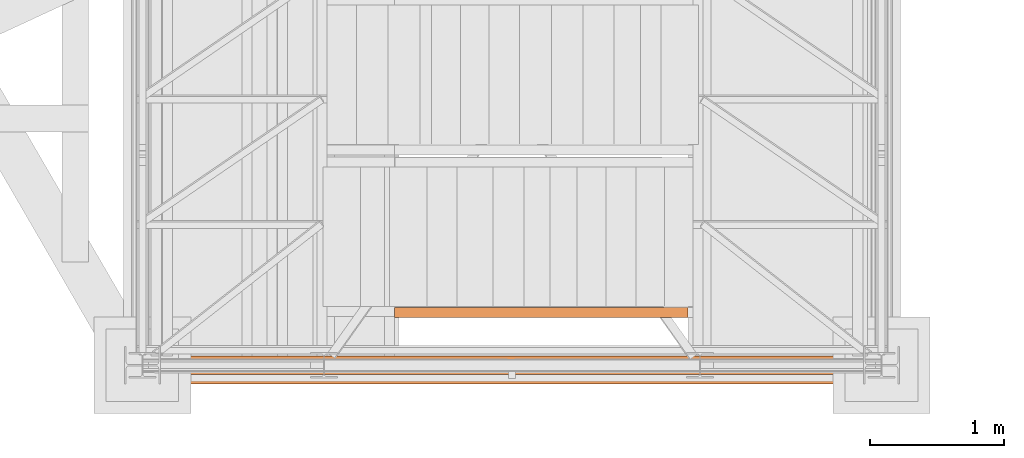
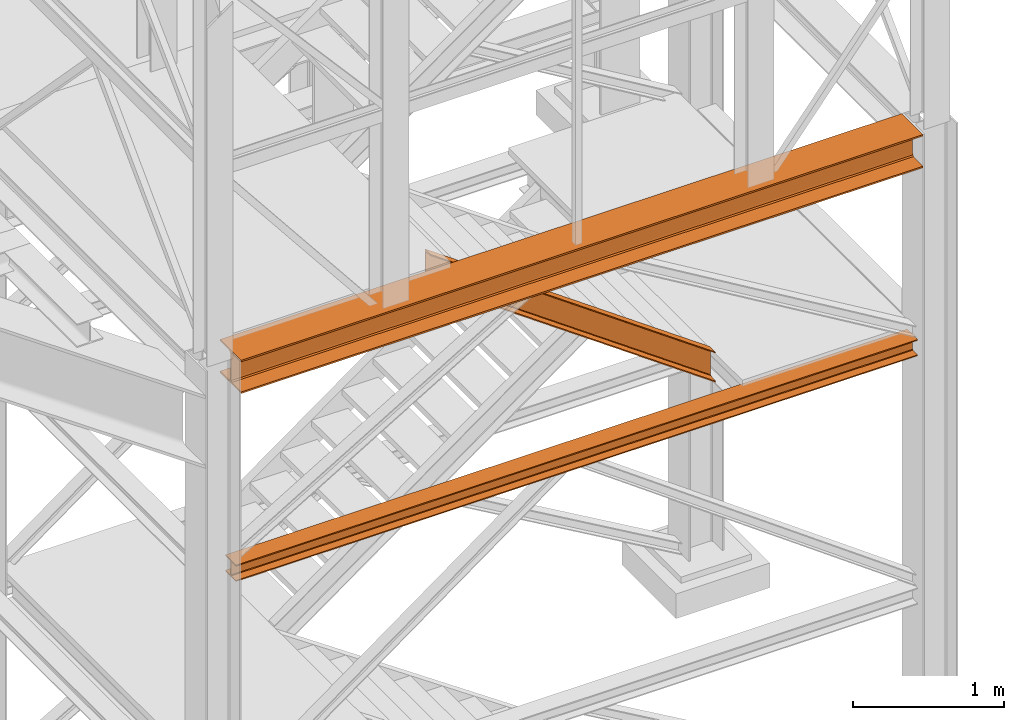
# One storey, part 41 of 208: 3 proxies.
"""IFC2X3 building model written with IfcOpenShell, lengths in millimetres."""

from ifc_helpers import new_model, entity, si_unit, converted_unit, frame, origin, origin_with_axes, place, context, subcontext, project, spatial, faceted_brep, element, save


model = new_model("IFC2X3")

# Units and contexts
model_context = context("Model", 3, precision=1e-05, world=origin())
plan_context = context("Plan", 3, precision=1e-05, world=origin())
body_context = subcontext(model_context, "Body", "Model", "MODEL_VIEW")
ifc_project = project(units=[si_unit("LENGTHUNIT", "METRE", prefix="MILLI"), converted_unit("PLANEANGLEUNIT", "DEGREE", entity("IfcPlaneAngleMeasure", 0.0174532925199433), si_unit("PLANEANGLEUNIT", "RADIAN"), dimensions=[0, 0, 0, 0, 0, 0, 0]), si_unit("AREAUNIT", "SQUARE_METRE"), si_unit("VOLUMEUNIT", "CUBIC_METRE")], contexts=[model_context, plan_context])

# Building, storey
building_placement = place(None, origin())
building = spatial("IfcBuilding", under=ifc_project, at=building_placement, CompositionType="COMPLEX")
storey_placement = place(building_placement, origin_with_axes())
storey = spatial("IfcBuildingStorey", under=building, at=storey_placement, Name="Geschoss", CompositionType="ELEMENT")

# Proxies
proxy_1_placement = place(storey_placement, frame((1333.254973893081, -25242.57439061591, 3447.489998909947), z_axis=(0.0, 0.0, 1.0), x_axis=(1.0, 0.0, 0.0)))
element("IfcBuildingElementProxy", 1, at=proxy_1_placement, inside=storey, context=body_context, shape_type="Brep", body=[
    faceted_brep([(0.01000000000021828, 0.01000000000567525, 8.510002324581365), (0.01000000000021828, 0.01000000000567525, 0.01000000000021828), (0.01000000000021828, 140.0100005960521, 0.01000000000021828), (0.01000000000021828, 140.0100005960521, 8.510002324581365), (0.01000000000021828, 84.76000038743587, 8.510002324581365), (0.01000000000021828, 78.54945996612878, 9.753034839630345), (0.01000000000021828, 74.00303279817672, 14.29946480155013), (0.01000000000021828, 72.76000051595838, 20.51000429153464), (0.01000000000021828, 72.76000051595838, 112.5100007450583), (0.01000000000021828, 74.00303279817672, 118.7205402350428), (0.01000000000021828, 78.54945996612878, 123.2669664716723), (0.01000000000021828, 84.76000038743587, 124.5099989867213), (0.01000000000021828, 140.0100005960521, 124.5099989867213), (0.01000000000021828, 140.0100005960521, 133.0100013113024), (0.01000000000021828, 0.01000000000567525, 133.0100013113024), (0.01000000000021828, 0.01000000000567525, 124.5099989867213), (0.01000000000021828, 55.26000020862193, 124.5099989867213), (0.01000000000021828, 61.47054062992902, 123.2669664716723), (0.01000000000021828, 66.01696779788108, 118.7205402350428), (0.01000000000021828, 67.26000008009942, 112.5100007450583), (0.01000000000021828, 67.26000008009942, 20.51000429153464), (0.01000000000021828, 66.01696779788108, 14.29946480155013), (0.01000000000021828, 61.47054062992902, 9.753034839630345), (0.01000000000021828, 55.26000020862193, 8.510002324581365), (0.01000000000021828, 0.01000000000567525, 0.01000000000021828), (0.01000000000021828, 0.01000000000567525, 8.510002324581365), (5230.009989271167, 0.01000000000203727, 8.510002324581365), (5230.009989271167, 0.01000000000203727, 0.01000000000021828), (0.01000000000021828, 140.0100005960521, 0.01000000000021828), (0.01000000000021828, 0.01000000000567525, 0.01000000000021828), (5230.009989271167, 0.01000000000203727, 0.01000000000021828), (5230.009989271167, 140.0100005960485, 0.01000000000021828), (0.01000000000021828, 140.0100005960521, 8.510002324581365), (0.01000000000021828, 140.0100005960521, 0.01000000000021828), (5230.009989271167, 140.0100005960485, 0.01000000000021828), (5230.009989271167, 140.0100005960485, 8.510002324581365), (0.01000000000021828, 84.76000038743587, 8.510002324581365), (0.01000000000021828, 140.0100005960521, 8.510002324581365), (5230.009989271167, 140.0100005960485, 8.510002324581365), (5230.009989271167, 84.76000038743223, 8.510002324581365), (0.01000000000021828, 78.54945996612878, 9.753034839630345), (0.01000000000021828, 84.76000038743587, 8.510002324581365), (5230.009989271167, 84.76000038743223, 8.510002324581365), (5230.009989271167, 78.54945996612514, 9.753034839630345), (0.01000000000021828, 74.00303279817672, 14.29946480155013), (0.01000000000021828, 78.54945996612878, 9.753034839630345), (5230.009989271167, 78.54945996612514, 9.753034839630345), (5230.009989271167, 74.00303279817308, 14.29946480155013), (0.01000000000021828, 72.76000051595838, 20.51000429153464), (0.01000000000021828, 74.00303279817672, 14.29946480155013), (5230.009989271167, 74.00303279817308, 14.29946480155013), (5230.009989271167, 72.76000051595474, 20.51000429153464), (0.01000000000021828, 72.76000051595838, 112.5100007450583), (0.01000000000021828, 72.76000051595838, 20.51000429153464), (5230.009989271167, 72.76000051595474, 20.51000429153464), (5230.009989271167, 72.76000051595474, 112.5100007450583), (0.01000000000021828, 74.00303279817672, 118.7205402350428), (0.01000000000021828, 72.76000051595838, 112.5100007450583), (5230.009989271167, 72.76000051595474, 112.5100007450583), (5230.009989271167, 74.00303279817308, 118.7205402350428), (0.01000000000021828, 78.54945996612878, 123.2669664716723), (0.01000000000021828, 74.00303279817672, 118.7205402350428), (5230.009989271167, 74.00303279817308, 118.7205402350428), (5230.009989271167, 78.54945996612514, 123.2669664716723), (0.01000000000021828, 84.76000038743587, 124.5099989867213), (0.01000000000021828, 78.54945996612878, 123.2669664716723), (5230.009989271167, 78.54945996612514, 123.2669664716723), (5230.009989271167, 84.76000038743223, 124.5099989867213), (0.01000000000021828, 140.0100005960521, 124.5099989867213), (0.01000000000021828, 84.76000038743587, 124.5099989867213), (5230.009989271167, 84.76000038743223, 124.5099989867213), (5230.009989271167, 140.0100005960485, 124.5099989867213), (0.01000000000021828, 140.0100005960521, 133.0100013113024), (0.01000000000021828, 140.0100005960521, 124.5099989867213), (5230.009989271167, 140.0100005960485, 124.5099989867213), (5230.009989271167, 140.0100005960485, 133.0100013113024), (0.01000000000021828, 0.01000000000567525, 133.0100013113024), (0.01000000000021828, 140.0100005960521, 133.0100013113024), (5230.009989271167, 140.0100005960485, 133.0100013113024), (5230.009989271167, 0.01000000000203727, 133.0100013113024), (0.01000000000021828, 0.01000000000567525, 124.5099989867213), (0.01000000000021828, 0.01000000000567525, 133.0100013113024), (5230.009989271167, 0.01000000000203727, 133.0100013113024), (5230.009989271167, 0.01000000000203727, 124.5099989867213), (0.01000000000021828, 55.26000020862193, 124.5099989867213), (0.01000000000021828, 0.01000000000567525, 124.5099989867213), (5230.009989271167, 0.01000000000203727, 124.5099989867213), (5230.009989271167, 55.26000020861829, 124.5099989867213), (0.01000000000021828, 61.47054062992902, 123.2669664716723), (0.01000000000021828, 55.26000020862193, 124.5099989867213), (5230.009989271167, 55.26000020861829, 124.5099989867213), (5230.009989271167, 61.47054062992538, 123.2669664716723), (0.01000000000021828, 66.01696779788108, 118.7205402350428), (0.01000000000021828, 61.47054062992902, 123.2669664716723), (5230.009989271167, 61.47054062992538, 123.2669664716723), (5230.009989271167, 66.01696779787744, 118.7205402350428), (0.01000000000021828, 67.26000008009942, 112.5100007450583), (0.01000000000021828, 66.01696779788108, 118.7205402350428), (5230.009989271167, 66.01696779787744, 118.7205402350428), (5230.009989271167, 67.26000008009578, 112.5100007450583), (0.01000000000021828, 67.26000008009942, 20.51000429153464), (0.01000000000021828, 67.26000008009942, 112.5100007450583), (5230.009989271167, 67.26000008009578, 112.5100007450583), (5230.009989271167, 67.26000008009578, 20.51000429153464), (0.01000000000021828, 66.01696779788108, 14.29946480155013), (0.01000000000021828, 67.26000008009942, 20.51000429153464), (5230.009989271167, 67.26000008009578, 20.51000429153464), (5230.009989271167, 66.01696779787744, 14.29946480155013), (0.01000000000021828, 61.47054062992902, 9.753034839630345), (0.01000000000021828, 66.01696779788108, 14.29946480155013), (5230.009989271167, 66.01696779787744, 14.29946480155013), (5230.009989271167, 61.47054062992538, 9.753034839630345), (0.01000000000021828, 55.26000020862193, 8.510002324581365), (0.01000000000021828, 61.47054062992902, 9.753034839630345), (5230.009989271167, 61.47054062992538, 9.753034839630345), (5230.009989271167, 55.26000020861829, 8.510002324581365), (0.01000000000021828, 0.01000000000567525, 8.510002324581365), (0.01000000000021828, 55.26000020862193, 8.510002324581365), (5230.009989271167, 55.26000020861829, 8.510002324581365), (5230.009989271167, 0.01000000000203727, 8.510002324581365), (5230.009989271167, 0.01000000000203727, 8.510002324581365), (5230.009989271167, 55.26000020861829, 8.510002324581365), (5230.009989271167, 61.47054062992538, 9.753034839630345), (5230.009989271167, 66.01696779787744, 14.29946480155013), (5230.009989271167, 67.26000008009578, 20.51000429153464), (5230.009989271167, 67.26000008009578, 112.5100007450583), (5230.009989271167, 66.01696779787744, 118.7205402350428), (5230.009989271167, 61.47054062992538, 123.2669664716723), (5230.009989271167, 55.26000020861829, 124.5099989867213), (5230.009989271167, 0.01000000000203727, 124.5099989867213), (5230.009989271167, 0.01000000000203727, 133.0100013113024), (5230.009989271167, 140.0100005960485, 133.0100013113024), (5230.009989271167, 140.0100005960485, 124.5099989867213), (5230.009989271167, 84.76000038743223, 124.5099989867213), (5230.009989271167, 78.54945996612514, 123.2669664716723), (5230.009989271167, 74.00303279817308, 118.7205402350428), (5230.009989271167, 72.76000051595474, 112.5100007450583), (5230.009989271167, 72.76000051595474, 20.51000429153464), (5230.009989271167, 74.00303279817308, 14.29946480155013), (5230.009989271167, 78.54945996612514, 9.753034839630345), (5230.009989271167, 84.76000038743223, 8.510002324581365), (5230.009989271167, 140.0100005960485, 8.510002324581365), (5230.009989271167, 140.0100005960485, 0.01000000000021828), (5230.009989271167, 0.01000000000203727, 0.01000000000021828)], [[[0, 1, 2, 3, 4, 5, 6, 7, 8, 9, 10, 11, 12, 13, 14, 15, 16, 17, 18, 19, 20, 21, 22, 23]], [[24, 25, 26, 27]], [[28, 29, 30, 31]], [[32, 33, 34, 35]], [[36, 37, 38, 39]], [[40, 41, 42, 43]], [[44, 45, 46, 47]], [[48, 49, 50, 51]], [[52, 53, 54, 55]], [[56, 57, 58, 59]], [[60, 61, 62, 63]], [[64, 65, 66, 67]], [[68, 69, 70, 71]], [[72, 73, 74, 75]], [[76, 77, 78, 79]], [[80, 81, 82, 83]], [[84, 85, 86, 87]], [[88, 89, 90, 91]], [[92, 93, 94, 95]], [[96, 97, 98, 99]], [[100, 101, 102, 103]], [[104, 105, 106, 107]], [[108, 109, 110, 111]], [[112, 113, 114, 115]], [[116, 117, 118, 119]], [[120, 121, 122, 123, 124, 125, 126, 127, 128, 129, 130, 131, 132, 133, 134, 135, 136, 137, 138, 139, 140, 141, 142, 143]]], orient=[[False], [False], [False], [False], [False], [False], [False], [False], [False], [False], [False], [False], [False], [False], [False], [False], [False], [False], [False], [False], [False], [False], [False], [False], [False], [False]]),
])
proxy_2_placement = place(storey_placement, frame((1333.254973893082, -25312.57439091393, 5014.98999463558), z_axis=(0.0, 0.0, 1.0), x_axis=(1.0, 0.0, 0.0)))
element("IfcBuildingElementProxy", 2, at=proxy_2_placement, inside=storey, context=body_context, shape_type="Brep", body=[
    faceted_brep([(5230.009989271167, 0.00999999999839929, 270.0100107288363), (0.01000000000112777, 0.00999999999839929, 270.0100107288363), (0.01000000000112777, 280.0100011920913, 270.0100107288363), (5230.009989271168, 280.0100011920913, 270.0100107288363), (5230.009989271168, 280.0100011920913, 270.0100107288363), (0.01000000000112777, 280.0100011920913, 270.0100107288363), (0.01000000000112777, 280.0100011920913, 257.0100141859057), (5230.009989271168, 280.0100011920913, 257.0100141859057), (5230.009989271168, 280.0100011920913, 257.0100141859057), (0.01000000000112777, 280.0100011920913, 257.0100141859057), (0.01000000000112777, 168.0100014603158, 257.0100141859057), (5230.009989271168, 168.0100014603122, 257.0100141859057), (5230.009989271168, 168.0100014603122, 257.0100141859057), (0.01000000000112777, 168.0100014603158, 257.0100141859057), (0.01000000000112777, 155.588920617698, 254.5239491558077), (5230.009989271167, 155.588920617698, 254.5239491558077), (5230.009989271167, 155.588920617698, 254.5239491558077), (0.01000000000112777, 155.588920617698, 254.5239491558077), (0.01000000000112777, 146.49606488481, 245.4310892319681), (5230.009989271168, 146.49606488481, 245.4310892319681), (5230.009989271168, 146.49606488481, 245.4310892319681), (0.01000000000112777, 146.49606488481, 245.4310892319681), (0.01000000000112777, 144.0100007860347, 233.0100102519991), (5230.009989271168, 144.0100007860347, 233.0100102519991), (5230.009989271168, 144.0100007860347, 233.0100102519991), (0.01000000000112777, 144.0100007860347, 233.0100102519991), (0.01000000000112777, 144.0100007860347, 37.01000047683738), (5230.009989271168, 144.0100007860347, 37.01000047683738), (5230.009989271168, 144.0100007860347, 37.01000047683738), (0.01000000000112777, 144.0100007860347, 37.01000047683738), (0.01000000000112777, 146.49606488481, 24.58892149686835), (5230.009989271169, 146.49606488481, 24.58892149686835), (5230.009989271169, 146.49606488481, 24.58892149686835), (0.01000000000112777, 146.49606488481, 24.58892149686835), (0.01000000000112777, 155.5889206177017, 15.49606157302878), (5230.009989271168, 155.588920617698, 15.49606157302878), (5230.009989271168, 155.588920617698, 15.49606157302878), (0.01000000000112777, 155.5889206177017, 15.49606157302878), (0.01000000000112777, 168.0100014603122, 13.00999654293082), (5230.009989271168, 168.0100014603122, 13.00999654293082), (5230.009989271168, 168.0100014603122, 13.00999654293082), (0.01000000000112777, 168.0100014603122, 13.00999654293082), (0.01000000000112777, 280.0100011920913, 13.00999654293082), (5230.009989271168, 280.0100011920913, 13.00999654293082), (5230.009989271168, 280.0100011920913, 13.00999654293082), (0.01000000000112777, 280.0100011920913, 13.00999654293082), (0.01000000000112777, 280.0100011920913, 0.01000000000021828), (5230.009989271168, 280.0100011920913, 0.01000000000021828), (5230.009989271168, 280.0100011920913, 0.01000000000021828), (0.01000000000112777, 280.0100011920913, 0.01000000000021828), (0.01000000000112777, 0.00999999999839929, 0.01000000000021828), (5230.009989271167, 0.00999999999839929, 0.01000000000021828), (5230.009989271167, 0.00999999999839929, 0.01000000000021828), (0.01000000000112777, 0.00999999999839929, 0.01000000000021828), (0.01000000000112777, 0.00999999999839929, 13.00999654293173), (5230.009989271168, 0.00999999999839929, 13.00999654293082), (5230.009989271168, 0.00999999999839929, 13.00999654293082), (0.01000000000112777, 0.00999999999839929, 13.00999654293173), (0.01000000000203727, 112.0099997317811, 13.00999654293082), (5230.009989271168, 112.0099997317775, 13.00999654293082), (5230.009989271168, 112.0099997317775, 13.00999654293082), (0.01000000000203727, 112.0099997317811, 13.00999654293082), (0.01000000000203727, 124.4310805743917, 15.49606157302878), (5230.009989271168, 124.4310805743917, 15.49606157302878), (5230.009989271168, 124.4310805743917, 15.49606157302878), (0.01000000000203727, 124.4310805743917, 15.49606157302878), (0.01000000000112777, 133.5239363072833, 24.58892149686835), (5230.009989271167, 133.5239363072797, 24.58892149686835), (5230.009989271167, 133.5239363072797, 24.58892149686835), (0.01000000000112777, 133.5239363072833, 24.58892149686835), (0.01000000000112777, 136.010000406055, 37.01000047683738), (5230.009989271168, 136.010000406055, 37.01000047683738), (5230.009989271168, 136.010000406055, 37.01000047683738), (0.01000000000112777, 136.010000406055, 37.01000047683738), (0.01000000000112777, 136.010000406055, 233.0100102519991), (5230.009989271168, 136.010000406055, 233.0100102519991), (5230.009989271168, 136.010000406055, 233.0100102519991), (0.01000000000112777, 136.010000406055, 233.0100102519991), (0.01000000000021828, 133.5239363072797, 245.4310892319681), (5230.009989271169, 133.5239363072797, 245.4310892319681), (5230.009989271169, 133.5239363072797, 245.4310892319681), (0.01000000000021828, 133.5239363072797, 245.4310892319681), (0.01000000000203727, 124.4310805743953, 254.5239491558077), (5230.009989271168, 124.4310805743917, 254.5239491558077), (5230.009989271168, 124.4310805743917, 254.5239491558077), (0.01000000000203727, 124.4310805743953, 254.5239491558077), (0.01000000000203727, 112.0099997317811, 257.0100141859057), (5230.009989271168, 112.0099997317775, 257.0100141859057), (5230.009989271168, 112.0099997317775, 257.0100141859057), (0.01000000000203727, 112.0099997317811, 257.0100141859057), (0.01000000000112777, 0.00999999999839929, 257.0100141859057), (5230.009989271167, 0.00999999999839929, 257.0100141859057), (5230.009989271167, 0.00999999999839929, 257.0100141859057), (0.01000000000112777, 0.00999999999839929, 257.0100141859057), (0.01000000000112777, 0.00999999999839929, 270.0100107288363), (5230.009989271167, 0.00999999999839929, 270.0100107288363), (5230.009989271168, 280.0100011920913, 0.01000000000021828), (5230.009989271167, 0.00999999999839929, 0.01000000000021828), (5230.009989271168, 0.00999999999839929, 13.00999654293082), (5230.009989271168, 112.0099997317775, 13.00999654293082), (5230.009989271168, 124.4310805743917, 15.49606157302878), (5230.009989271167, 133.5239363072797, 24.58892149686835), (5230.009989271168, 136.010000406055, 37.01000047683738), (5230.009989271168, 136.010000406055, 233.0100102519991), (5230.009989271169, 133.5239363072797, 245.4310892319681), (5230.009989271168, 124.4310805743917, 254.5239491558077), (5230.009989271168, 112.0099997317775, 257.0100141859057), (5230.009989271167, 0.00999999999839929, 257.0100141859057), (5230.009989271167, 0.00999999999839929, 270.0100107288363), (5230.009989271168, 280.0100011920913, 270.0100107288363), (5230.009989271168, 280.0100011920913, 257.0100141859057), (5230.009989271168, 168.0100014603122, 257.0100141859057), (5230.009989271167, 155.588920617698, 254.5239491558077), (5230.009989271168, 146.49606488481, 245.4310892319681), (5230.009989271168, 144.0100007860347, 233.0100102519991), (5230.009989271168, 144.0100007860347, 37.01000047683738), (5230.009989271169, 146.49606488481, 24.58892149686835), (5230.009989271168, 155.588920617698, 15.49606157302878), (5230.009989271168, 168.0100014603122, 13.00999654293082), (5230.009989271168, 280.0100011920913, 13.00999654293082), (0.01000000000112777, 0.00999999999839929, 0.01000000000021828), (0.01000000000112777, 280.0100011920913, 0.01000000000021828), (0.01000000000112777, 280.0100011920913, 13.00999654293082), (0.01000000000112777, 168.0100014603122, 13.00999654293082), (0.01000000000112777, 155.5889206177017, 15.49606157302878), (0.01000000000112777, 146.49606488481, 24.58892149686835), (0.01000000000112777, 144.0100007860347, 37.01000047683738), (0.01000000000112777, 144.0100007860347, 233.0100102519991), (0.01000000000112777, 146.49606488481, 245.4310892319681), (0.01000000000112777, 155.588920617698, 254.5239491558077), (0.01000000000112777, 168.0100014603158, 257.0100141859057), (0.01000000000112777, 280.0100011920913, 257.0100141859057), (0.01000000000112777, 280.0100011920913, 270.0100107288363), (0.01000000000112777, 0.00999999999839929, 270.0100107288363), (0.01000000000112777, 0.00999999999839929, 257.0100141859057), (0.01000000000203727, 112.0099997317811, 257.0100141859057), (0.01000000000203727, 124.4310805743953, 254.5239491558077), (0.01000000000021828, 133.5239363072797, 245.4310892319681), (0.01000000000112777, 136.010000406055, 233.0100102519991), (0.01000000000112777, 136.010000406055, 37.01000047683738), (0.01000000000112777, 133.5239363072833, 24.58892149686835), (0.01000000000203727, 124.4310805743917, 15.49606157302878), (0.01000000000203727, 112.0099997317811, 13.00999654293082), (0.01000000000112777, 0.00999999999839929, 13.00999654293173)], [[[0, 1, 2, 3]], [[4, 5, 6, 7]], [[8, 9, 10, 11]], [[12, 13, 14, 15]], [[16, 17, 18, 19]], [[20, 21, 22, 23]], [[24, 25, 26, 27]], [[28, 29, 30, 31]], [[32, 33, 34, 35]], [[36, 37, 38, 39]], [[40, 41, 42, 43]], [[44, 45, 46, 47]], [[48, 49, 50, 51]], [[52, 53, 54, 55]], [[56, 57, 58, 59]], [[60, 61, 62, 63]], [[64, 65, 66, 67]], [[68, 69, 70, 71]], [[72, 73, 74, 75]], [[76, 77, 78, 79]], [[80, 81, 82, 83]], [[84, 85, 86, 87]], [[88, 89, 90, 91]], [[92, 93, 94, 95]], [[96, 97, 98, 99, 100, 101, 102, 103, 104, 105, 106, 107, 108, 109, 110, 111, 112, 113, 114, 115, 116, 117, 118, 119]], [[120, 121, 122, 123, 124, 125, 126, 127, 128, 129, 130, 131, 132, 133, 134, 135, 136, 137, 138, 139, 140, 141, 142, 143]]], orient=[[False], [False], [False], [False], [False], [False], [False], [False], [False], [False], [False], [False], [False], [False], [False], [False], [False], [False], [False], [False], [False], [False], [False], [False], [False], [False]]),
])
proxy_3_placement = place(storey_placement, frame((3073.108528797206, -24817.42795058643, 3431.295585532193), z_axis=(0.0, 0.0, 1.0), x_axis=(1.0, 0.0, 0.0)))
element("IfcBuildingElementProxy", 3, at=proxy_3_placement, inside=storey, context=body_context, shape_type="Brep", body=[
    faceted_brep([(0.01000000000112777, 75.01000111758549, 1802.407642942483), (0.01000000000112777, 75.01000111758549, 1556.84425687791), (2185.302879462911, 75.01000111758549, 0.01000000000021828), (2185.302879462911, 75.01000111758549, 245.5733860645728), (0.01000000000112777, 0.00999999999839929, 1802.407642942482), (0.01000000000112777, 75.01000111758549, 1802.407642942483), (2185.302879462911, 75.01000111758549, 245.5733860645728), (2185.302879462911, 0.00999999999839929, 245.5733860645728), (0.01000000000021828, 0.00999999999839929, 1798.77228465679), (0.01000000000112777, 0.00999999999839929, 1802.407642942482), (2185.302879462911, 0.00999999999839929, 245.5733860645728), (2185.302879462911, 0.00999999999839929, 241.93802777888), (0.01000000000203727, 1.126000115869829, 1793.372341923438), (0.01000000000021828, 0.00999999999839929, 1798.77228465679), (2185.302879462911, 0.00999999999839929, 241.93802777888), (2185.302879462911, 1.126000115869829, 236.5380850455285), (0.01000000000203727, 5.531528422830888, 1791.428841891952), (0.01000000000203727, 1.126000115869829, 1793.372341923438), (2185.302879462911, 1.126000115869829, 236.5380850455285), (2185.302879462911, 5.531528422830888, 234.5945850140433), (0.01000000000203727, 55.92706931590874, 1786.478722100011), (0.01000000000203727, 5.531528422830888, 1791.428841891952), (2185.302879462911, 5.531528422830888, 234.5945850140433), (2185.302879462911, 55.92706931590874, 229.6444652221016), (0.01000000000112777, 61.66620032697756, 1784.52008221316), (0.01000000000203727, 55.92706931590874, 1786.478722100011), (2185.302879462911, 55.92706931590874, 229.6444652221016), (2185.302879462911, 61.66620032697756, 227.6858253352507), (0.01000000000112777, 65.51985109060843, 1779.264658775921), (0.01000000000112777, 61.66620032697756, 1784.52008221316), (2185.302879462911, 61.66620032697756, 227.6858253352507), (2185.302879462911, 65.51985109060843, 222.4304018980106), (0.01000000000112777, 66.51000065564949, 1772.403797757367), (0.01000000000112777, 65.51985109060843, 1779.264658775921), (2185.302879462911, 65.51985109060843, 222.4304018980106), (2185.302879462911, 66.51000065564949, 215.5695408794572), (0.01000000000112777, 66.51000065564949, 1586.848102063029), (0.01000000000112777, 66.51000065564949, 1772.403797757367), (2185.302879462911, 66.51000065564949, 215.5695408794572), (2185.302879462911, 66.51000065564949, 30.0138451851185), (0.01000000000021828, 65.51985109060843, 1579.987241044472), (0.01000000000112777, 66.51000065564949, 1586.848102063029), (2185.302879462911, 66.51000065564949, 30.0138451851185), (2185.302879462911, 65.51985109060843, 23.15298416656242), (0.01000000000112777, 61.66620032697756, 1574.731817607232), (0.01000000000021828, 65.51985109060843, 1579.987241044472), (2185.302879462911, 65.51985109060843, 23.15298416656242), (2185.302879462911, 61.66620032697756, 17.89756072932232), (0.01000000000203727, 55.92706931590874, 1572.773177720382), (0.01000000000112777, 61.66620032697756, 1574.731817607232), (2185.302879462911, 61.66620032697756, 17.89756072932232), (2185.302879462911, 55.92706931590874, 15.93892084247273), (0.01000000000112777, 5.531528422830888, 1567.823057928443), (0.01000000000203727, 55.92706931590874, 1572.773177720382), (2185.302879462911, 55.92706931590874, 15.93892084247273), (2185.302879462911, 5.531528422830888, 10.98880105053149), (0.01000000000112777, 1.126000115869829, 1565.879557896956), (0.01000000000112777, 5.531528422830888, 1567.823057928443), (2185.302879462911, 5.531528422830888, 10.98880105053149), (2185.302879462911, 1.126000115869829, 9.045301019044928), (0.01000000000021828, 0.00999999999839929, 1560.479615163604), (0.01000000000112777, 1.126000115869829, 1565.879557896956), (2185.302879462911, 1.126000115869829, 9.045301019044928), (2185.302879462911, 0.00999999999839929, 3.645358285694329), (0.01000000000021828, 0.00999999999839929, 1556.844256877911), (0.01000000000021828, 0.00999999999839929, 1560.479615163604), (2185.302879462911, 0.00999999999839929, 3.645358285694329), (2185.302879462911, 0.00999999999839929, 0.01000000000021828), (0.01000000000112777, 75.01000111758549, 1556.84425687791), (0.01000000000021828, 0.00999999999839929, 1556.844256877911), (2185.302879462911, 0.00999999999839929, 0.01000000000021828), (2185.302879462911, 75.01000111758549, 0.01000000000021828), (2185.302879462911, 75.01000111758549, 0.01000000000021828), (2185.302879462911, 0.00999999999839929, 0.01000000000021828), (2185.302879462911, 0.00999999999839929, 3.645358285694329), (2185.302879462911, 1.126000115869829, 9.045301019044928), (2185.302879462911, 5.531528422830888, 10.98880105053149), (2185.302879462911, 55.92706931590874, 15.93892084247273), (2185.302879462911, 61.66620032697756, 17.89756072932232), (2185.302879462911, 65.51985109060843, 23.15298416656242), (2185.302879462911, 66.51000065564949, 30.0138451851185), (2185.302879462911, 66.51000065564949, 215.5695408794572), (2185.302879462911, 65.51985109060843, 222.4304018980106), (2185.302879462911, 61.66620032697756, 227.6858253352507), (2185.302879462911, 55.92706931590874, 229.6444652221016), (2185.302879462911, 5.531528422830888, 234.5945850140433), (2185.302879462911, 1.126000115869829, 236.5380850455285), (2185.302879462911, 0.00999999999839929, 241.93802777888), (2185.302879462911, 0.00999999999839929, 245.5733860645728), (2185.302879462911, 75.01000111758549, 245.5733860645728), (0.01000000000112777, 75.01000111758549, 1802.407642942483), (0.01000000000112777, 0.00999999999839929, 1802.407642942482), (0.01000000000021828, 0.00999999999839929, 1798.77228465679), (0.01000000000203727, 1.126000115869829, 1793.372341923438), (0.01000000000203727, 5.531528422830888, 1791.428841891952), (0.01000000000203727, 55.92706931590874, 1786.478722100011), (0.01000000000112777, 61.66620032697756, 1784.52008221316), (0.01000000000112777, 65.51985109060843, 1779.264658775921), (0.01000000000112777, 66.51000065564949, 1772.403797757367), (0.01000000000112777, 66.51000065564949, 1586.848102063029), (0.01000000000021828, 65.51985109060843, 1579.987241044472), (0.01000000000112777, 61.66620032697756, 1574.731817607232), (0.01000000000203727, 55.92706931590874, 1572.773177720382), (0.01000000000112777, 5.531528422830888, 1567.823057928443), (0.01000000000112777, 1.126000115869829, 1565.879557896956), (0.01000000000021828, 0.00999999999839929, 1560.479615163604), (0.01000000000021828, 0.00999999999839929, 1556.844256877911), (0.01000000000112777, 75.01000111758549, 1556.84425687791)], [[[0, 1, 2, 3]], [[4, 5, 6, 7]], [[8, 9, 10, 11]], [[12, 13, 14, 15]], [[16, 17, 18, 19]], [[20, 21, 22, 23]], [[24, 25, 26, 27]], [[28, 29, 30, 31]], [[32, 33, 34, 35]], [[36, 37, 38, 39]], [[40, 41, 42, 43]], [[44, 45, 46, 47]], [[48, 49, 50, 51]], [[52, 53, 54, 55]], [[56, 57, 58, 59]], [[60, 61, 62, 63]], [[64, 65, 66, 67]], [[68, 69, 70, 71]], [[72, 73, 74, 75, 76, 77, 78, 79, 80, 81, 82, 83, 84, 85, 86, 87, 88, 89]], [[90, 91, 92, 93, 94, 95, 96, 97, 98, 99, 100, 101, 102, 103, 104, 105, 106, 107]]], orient=[[False], [False], [False], [False], [False], [False], [False], [False], [False], [False], [False], [False], [False], [False], [False], [False], [False], [False], [False], [False]]),
])

save(model, "model.ifc")
